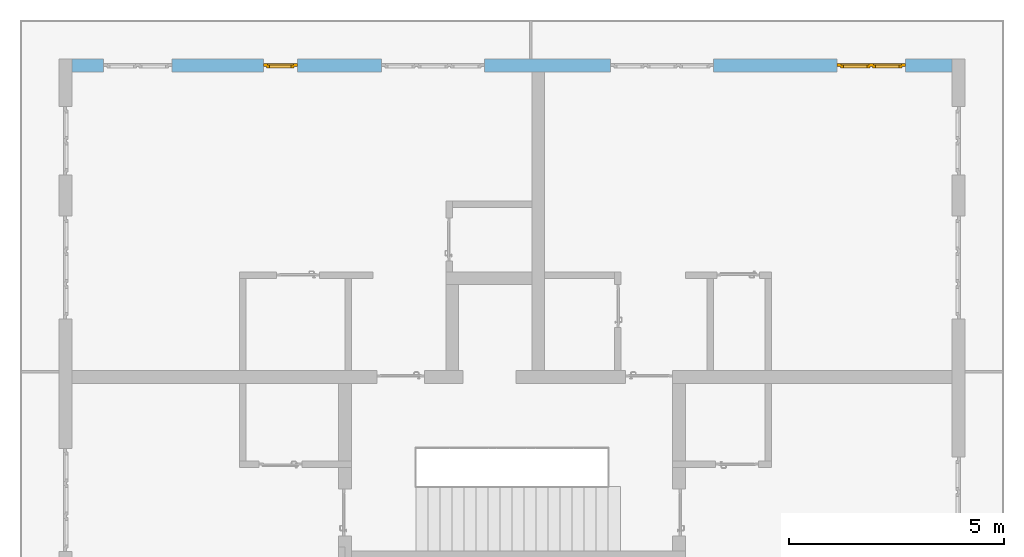
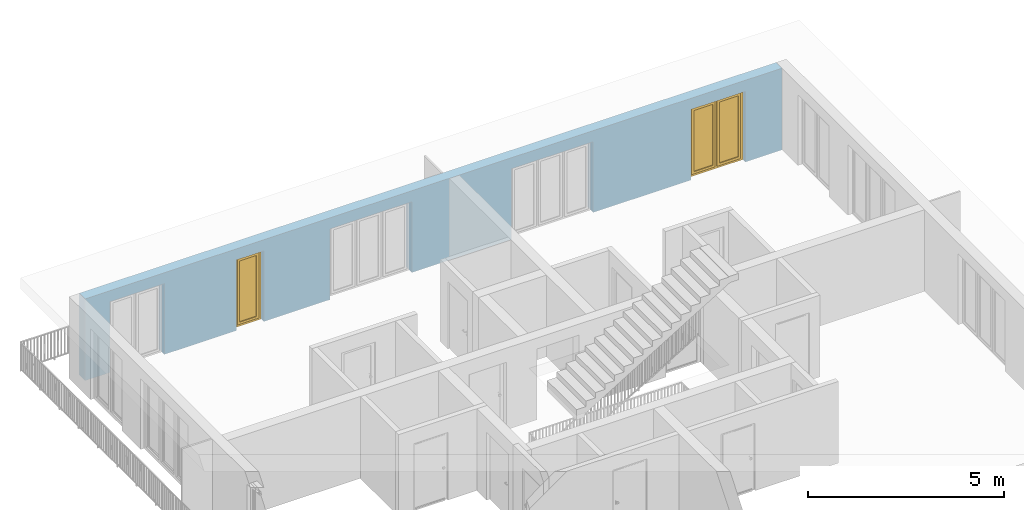
# One storey, part 22 of 48: 2 windows, 5 openings, plus 1 element that does not belong to this part.
"""IFC4 building model written with IfcOpenShell, lengths in metres."""

from ifc_helpers import new_model, entity, si_unit, converted_unit, derived_unit, direction, frame, origin_with_axes, place, context, subcontext, project, spatial, polygons, source, transform, mapped, material, type_object, element, fill, save


model = new_model("IFC4")

# Units and contexts
model_context = context("Model", 3, precision=1e-05, world=origin_with_axes(), true_north=direction((0.0, 1.0)))
body_context = subcontext(model_context, "Body", "Model", "MODEL_VIEW")
ifc_project = project(units=[si_unit("LENGTHUNIT", "METRE"), si_unit("AREAUNIT", "SQUARE_METRE"), si_unit("VOLUMEUNIT", "CUBIC_METRE"), converted_unit("PLANEANGLEUNIT", "DEGREE", entity("IfcPlaneAngleMeasure", 0.0174532925199), si_unit("PLANEANGLEUNIT", "RADIAN"), dimensions=[0, 0, 0, 0, 0, 0, 0]), converted_unit("TIMEUNIT", "Year", entity("IfcTimeMeasure", 31556926.0), si_unit("TIMEUNIT", "SECOND"), dimensions=[0, 0, 1, 0, 0, 0, 0]), si_unit("MASSUNIT", "GRAM", prefix="KILO"), si_unit("THERMODYNAMICTEMPERATUREUNIT", "DEGREE_CELSIUS"), si_unit("LUMINOUSINTENSITYUNIT", "LUMEN"), si_unit("ENERGYUNIT", "JOULE", prefix="MEGA"), derived_unit("THERMALCONDUCTANCEUNIT", [(si_unit("POWERUNIT", "WATT"), 1), (si_unit("LENGTHUNIT", "METRE"), -1), (si_unit("THERMODYNAMICTEMPERATUREUNIT", "KELVIN"), -1)]), derived_unit("SPECIFICHEATCAPACITYUNIT", [(si_unit("ENERGYUNIT", "JOULE"), 1), (si_unit("MASSUNIT", "GRAM", prefix="KILO"), -1), (si_unit("THERMODYNAMICTEMPERATUREUNIT", "KELVIN"), -1)]), derived_unit("MASSDENSITYUNIT", [(si_unit("MASSUNIT", "GRAM", prefix="KILO"), 1), (si_unit("VOLUMEUNIT", "CUBIC_METRE"), -1)])], contexts=[model_context])

# Site, building, storey
site_placement = place(None, origin_with_axes())
site = spatial("IfcSite", under=ifc_project, at=site_placement, CompositionType="ELEMENT")
building_placement = place(site_placement, origin_with_axes())
building = spatial("IfcBuilding", under=site, at=building_placement, CompositionType="ELEMENT")
storey_placement = place(building_placement, frame((0.0, 0.0, 3.4), z_axis=(0.0, 0.0, 1.0), x_axis=(1.0, 0.0, 0.0)))
storey = spatial("IfcBuildingStorey", under=building, at=storey_placement, Name="1. Geschoss", CompositionType="ELEMENT", Elevation=3.4)

# Wall, openings, windows
ifc_material = material()
wall_type = type_object("IfcWallType", Name="300", PredefinedType="NOTDEFINED")
wall_placement = place(storey_placement, frame((-11.7421993804, 8.92118776896, 0.0), z_axis=(0.0, 0.0, 1.0), x_axis=(1.0, 0.0, 0.0)))
wall = element("IfcWall", 1, at=wall_placement, inside=storey, type_object=wall_type, material=ifc_material, Name="Wand-001", PredefinedType="NOTDEFINED", context=body_context, shape_type="Tessellation", body=[
    polygons([(15.23, -0.1, 0.0), (15.23, -0.3, 0.0), (15.23, -0.3, 2.2), (15.23, 0.0, 2.2), (15.23, 0.0, 0.0), (18.102139809, 0.0, 0.0), (18.102139809, -0.3, 0.0), (18.102139809, -0.3, 2.2), (19.702139809, -0.3, 2.2), (19.702139809, -0.3, 0.0), (20.78, -0.3, 0.0), (20.78, -0.3, 2.54), (0.3, -0.3, 2.54), (0.3, -0.3, 0.0), (1.0288518641, -0.3, 0.0), (1.0288518641, -0.3, 2.2), (2.6288518641, -0.3, 2.2), (2.6288518641, -0.3, 0.0), (4.75, -0.3, 0.0), (4.75, -0.3, 2.2), (5.55, -0.3, 2.2), (5.55, -0.3, 0.0), (7.50089858046, -0.3, 0.0), (7.50089858046, -0.3, 2.2), (9.90089858046, -0.3, 2.2), (9.90089858046, -0.3, 0.0), (12.83, -0.3, 0.0), (12.83, -0.3, 2.2), (12.83, 0.0, 2.2), (12.83, 0.0, 0.0), (9.90089858046, 0.0, 0.0), (9.90089858046, 0.0, 2.2), (7.50089858046, 0.0, 2.2), (7.50089858046, 0.0, 0.0), (5.55, 0.0, 0.0), (5.55, 0.0, 2.2), (4.75, 0.0, 2.2), (4.75, 0.0, 0.0), (2.6288518641, 0.0, 0.0), (2.6288518641, 0.0, 2.2), (1.0288518641, 0.0, 2.2), (1.0288518641, 0.0, 0.0), (0.3, 0.0, 0.0), (0.3, 0.0, 2.54), (20.78, 0.0, 2.54), (20.78, 0.0, 0.0), (19.702139809, 0.0, 0.0), (19.702139809, 0.0, 2.2), (18.102139809, 0.0, 2.2), (12.83, -0.1, 0.0)], [[[1, 2, 3, 4, 5]], [[2, 1, 5, 6, 7]], [[3, 2, 7, 8, 9, 10, 11, 12, 13, 14, 15, 16, 17, 18, 19, 20, 21, 22, 23, 24, 25, 26, 27, 28]], [[4, 3, 28, 29]], [[6, 5, 4, 29, 30, 31, 32, 33, 34, 35, 36, 37, 38, 39, 40, 41, 42, 43, 44, 45, 46, 47, 48, 49]], [[6, 49, 8, 7]], [[8, 49, 48, 9]], [[48, 47, 10, 9]], [[46, 11, 10, 47]], [[12, 11, 46, 45]], [[45, 44, 13, 12]], [[44, 43, 14, 13]], [[15, 14, 43, 42]], [[16, 15, 42, 41]], [[40, 17, 16, 41]], [[18, 17, 40, 39]], [[19, 18, 39, 38]], [[20, 19, 38, 37]], [[36, 21, 20, 37]], [[22, 21, 36, 35]], [[22, 35, 34, 23]], [[34, 33, 24, 23]], [[24, 33, 32, 25]], [[32, 31, 26, 25]], [[50, 27, 26, 31, 30]], [[28, 27, 50, 30, 29]]], closed=True),
])
opening_1_placement = place(wall_placement, frame((1.8288518641, 0.0, 0.0), z_axis=(0.0, 0.0, 1.0), x_axis=(1.0, 0.0, 0.0)))
element("IfcOpeningElement", 2, at=opening_1_placement, cuts=wall, Name="Fenster-001", context=body_context, identifier="Reference", shape_type="Tessellation", body=[
    polygons([(-0.8, -0.1, 0.0), (-0.8, -0.1, 2.2), (-0.8, 0.000999999999998, 2.2), (-0.8, 0.000999999999998, 0.0), (-0.8, -0.301, 0.0), (-0.8, -0.301, 2.2), (0.8, -0.1, 2.2), (0.8, 0.000999999999999, 2.2), (0.8, -0.301, 2.2), (0.8, 0.000999999999999, 0.0), (0.8, -0.1, 0.0), (0.8, -0.301, 0.0)], [[[1, 2, 3, 4]], [[2, 1, 5, 6]], [[7, 8, 3, 2, 6, 9]], [[8, 10, 4, 3]], [[1, 4, 10, 11, 12, 5]], [[6, 5, 12, 9]], [[7, 11, 10, 8]], [[11, 7, 9, 12]]], closed=True),
])
opening_2_placement = place(wall_placement, frame((8.70089858046, 0.0, 0.0), z_axis=(0.0, 0.0, 1.0), x_axis=(1.0, 0.0, 0.0)))
element("IfcOpeningElement", 3, at=opening_2_placement, cuts=wall, Name="Fenster-002", context=body_context, identifier="Reference", shape_type="Tessellation", body=[
    polygons([(-1.2, -0.1, 0.0), (-1.2, -0.1, 2.2), (-1.2, 0.000999999999999, 2.2), (-1.2, 0.000999999999999, 0.0), (-1.2, -0.301, 0.0), (-1.2, -0.301, 2.2), (1.2, -0.1, 2.2), (1.2, 0.001, 2.2), (1.2, -0.301, 2.2), (1.2, 0.001, 0.0), (1.2, -0.1, 0.0), (1.2, -0.301, 0.0)], [[[1, 2, 3, 4]], [[2, 1, 5, 6]], [[7, 8, 3, 2, 6, 9]], [[8, 10, 4, 3]], [[1, 4, 10, 11, 12, 5]], [[6, 5, 12, 9]], [[7, 11, 10, 8]], [[11, 7, 9, 12]]], closed=True),
])
opening_3_placement = place(wall_placement, frame((5.15, 0.0, 0.0), z_axis=(0.0, 0.0, 1.0), x_axis=(1.0, 0.0, 0.0)))
opening_3 = element("IfcOpeningElement", 4, at=opening_3_placement, cuts=wall, Name="Fenster-003", context=body_context, identifier="Reference", shape_type="Tessellation", body=[
    polygons([(-0.4, -0.1, 0.0), (-0.4, -0.1, 2.2), (-0.4, 0.001, 2.2), (-0.4, 0.001, 0.0), (-0.4, -0.301, 0.0), (-0.4, -0.301, 2.2), (0.4, -0.1, 2.2), (0.4, 0.001, 2.2), (0.4, -0.301, 2.2), (0.4, 0.001, 0.0), (0.4, -0.1, 0.0), (0.4, -0.301, 0.0)], [[[1, 2, 3, 4]], [[2, 1, 5, 6]], [[7, 8, 3, 2, 6, 9]], [[8, 10, 4, 3]], [[1, 4, 10, 11, 12, 5]], [[6, 5, 12, 9]], [[7, 11, 10, 8]], [[11, 7, 9, 12]]], closed=True),
])
opening_4_placement = place(wall_placement, frame((18.902139809, 0.0, 0.0), z_axis=(0.0, 0.0, 1.0), x_axis=(1.0, 0.0, 0.0)))
opening_4 = element("IfcOpeningElement", 5, at=opening_4_placement, cuts=wall, Name="Fenster-001", context=body_context, identifier="Reference", shape_type="Tessellation", body=[
    polygons([(-0.8, -0.1, 0.0), (-0.8, -0.1, 2.2), (-0.8, 0.001, 2.2), (-0.8, 0.001, 0.0), (-0.8, -0.301, 0.0), (-0.8, -0.301, 2.2), (0.8, -0.1, 2.2), (0.8, 0.001, 2.2), (0.8, -0.301, 2.2), (0.8, 0.001, 0.0), (0.8, -0.1, 0.0), (0.8, -0.301, 0.0)], [[[1, 2, 3, 4]], [[2, 1, 5, 6]], [[7, 8, 3, 2, 6, 9]], [[8, 10, 4, 3]], [[1, 4, 10, 11, 12, 5]], [[6, 5, 12, 9]], [[7, 11, 10, 8]], [[11, 7, 9, 12]]], closed=True),
])
opening_5_placement = place(wall_placement, frame((14.03, 0.0, 0.0), z_axis=(0.0, 0.0, 1.0), x_axis=(1.0, 0.0, 0.0)))
element("IfcOpeningElement", 6, at=opening_5_placement, cuts=wall, Name="Fenster-002", context=body_context, identifier="Reference", shape_type="Tessellation", body=[
    polygons([(-1.2, -0.1, 0.0), (-1.2, -0.1, 2.2), (-1.2, 0.001, 2.2), (-1.2, 0.001, 0.0), (-1.2, -0.301, 0.0), (-1.2, -0.301, 2.2), (1.2, -0.1, 2.2), (1.2, 0.001, 2.2), (1.2, -0.301, 2.2), (1.2, 0.001, 0.0), (1.2, -0.1, 0.0), (1.2, -0.301, 0.0)], [[[1, 2, 3, 4]], [[2, 1, 5, 6]], [[7, 8, 3, 2, 6, 9]], [[8, 10, 4, 3]], [[1, 4, 10, 11, 12, 5]], [[6, 5, 12, 9]], [[7, 11, 10, 8]], [[11, 7, 9, 12]]], closed=True),
])
window_type_1 = type_object("IfcWindowType", Name="2-1+1 26", PartitioningType="DOUBLE_PANEL_VERTICAL", PredefinedType="WINDOW")
shared_shape_1 = source(origin_with_axes(), body_context, "Body", "Tessellation", [
    polygons([(-0.8, -0.07, 0.0), (-0.8, 0.0, 0.0), (-0.7, 0.0, 0.1), (-0.7, -0.07, 0.1), (-0.8, -0.07, 2.2), (-0.8, 0.0, 2.2), (-0.7, 0.0, 2.1), (-0.7, -0.07, 2.1)], [[[1, 2, 3, 4]], [[5, 6, 2, 1]], [[2, 6, 7, 3]], [[4, 3, 7, 8]], [[1, 4, 8, 5]], [[8, 7, 6, 5]]], closed=True),
    polygons([(0.8, -0.07, 0.0), (0.8, 0.0, 0.0), (0.8, 0.0, 2.2), (0.8, -0.07, 2.2), (0.7, -0.07, 0.1), (0.7, 0.0, 0.1), (0.7, 0.0, 2.1), (0.7, -0.07, 2.1)], [[[1, 2, 3, 4]], [[5, 6, 2, 1]], [[2, 6, 7, 3]], [[4, 3, 7, 8]], [[1, 4, 8, 5]], [[8, 7, 6, 5]]], closed=True),
    polygons([(-0.8, -0.07, 0.0), (-0.8, 0.0, 0.0), (0.8, 0.0, 0.0), (0.8, -0.07, 0.0), (-0.7, -0.07, 0.1), (-0.7, 0.0, 0.1), (-0.05, 0.0, 0.1), (0.05, 0.0, 0.1), (0.7, 0.0, 0.1), (0.7, -0.07, 0.1), (0.05, -0.07, 0.1), (-0.05, -0.07, 0.1)], [[[1, 2, 3, 4]], [[5, 6, 2, 1]], [[2, 6, 7, 8, 9, 3]], [[4, 3, 9, 10]], [[1, 4, 10, 11, 12, 5]], [[12, 7, 6, 5]], [[11, 8, 7, 12]], [[10, 9, 8, 11]]], closed=True),
    polygons([(-0.8, -0.07, 2.2), (-0.8, 0.0, 2.2), (-0.7, 0.0, 2.1), (-0.7, -0.07, 2.1), (0.8, -0.07, 2.2), (0.8, 0.0, 2.2), (0.7, 0.0, 2.1), (0.05, 0.0, 2.1), (-0.05, 0.0, 2.1), (-0.05, -0.07, 2.1), (0.05, -0.07, 2.1), (0.7, -0.07, 2.1)], [[[1, 2, 3, 4]], [[5, 6, 2, 1]], [[2, 6, 7, 8, 9, 3]], [[4, 3, 9, 10]], [[1, 4, 10, 11, 12, 5]], [[12, 7, 6, 5]], [[11, 8, 7, 12]], [[10, 9, 8, 11]]], closed=True),
    polygons([(-0.05, -0.07, 0.1), (-0.05, 0.0, 0.1), (0.05, 0.0, 0.1), (0.05, -0.07, 0.1), (-0.05, -0.07, 2.1), (-0.05, 0.0, 2.1), (0.05, 0.0, 2.1), (0.05, -0.07, 2.1)], [[[1, 2, 3, 4]], [[5, 6, 2, 1]], [[2, 6, 7, 3]], [[4, 3, 7, 8]], [[1, 4, 8, 5]], [[8, 7, 6, 5]]], closed=True),
    polygons([(-0.72, 0.0, 0.08), (-0.72, 0.03, 0.08), (-0.65, 0.03, 0.15), (-0.65, 0.0, 0.15), (-0.72, 0.0, 2.12), (-0.72, 0.03, 2.12), (-0.65, 0.03, 2.05), (-0.65, 0.0, 2.05)], [[[1, 2, 3, 4]], [[5, 6, 2, 1]], [[2, 6, 7, 3]], [[4, 3, 7, 8]], [[1, 4, 8, 5]], [[8, 7, 6, 5]]], closed=True),
    polygons([(-0.03, 0.0, 0.08), (-0.1, 0.0, 0.15), (-0.1, 0.03, 0.15), (-0.03, 0.03, 0.08), (-0.03, 0.0, 2.12), (-0.1, 0.0, 2.05), (-0.1, 0.03, 2.05), (-0.03, 0.03, 2.12)], [[[1, 2, 3, 4]], [[1, 5, 6, 2]], [[2, 6, 7, 3]], [[4, 3, 7, 8]], [[5, 1, 4, 8]], [[6, 5, 8, 7]]], closed=True),
    polygons([(-0.72, 0.0, 0.08), (-0.72, 0.03, 0.08), (-0.03, 0.03, 0.08), (-0.03, 0.0, 0.08), (-0.65, 0.0, 0.15), (-0.65, 0.03, 0.15), (-0.1, 0.03, 0.15), (-0.1, 0.0, 0.15)], [[[1, 2, 3, 4]], [[5, 6, 2, 1]], [[2, 6, 7, 3]], [[4, 3, 7, 8]], [[1, 4, 8, 5]], [[8, 7, 6, 5]]], closed=True),
    polygons([(-0.72, 0.0, 2.12), (-0.03, 0.0, 2.12), (-0.03, 0.03, 2.12), (-0.72, 0.03, 2.12), (-0.65, 0.0, 2.05), (-0.1, 0.0, 2.05), (-0.1, 0.03, 2.05), (-0.65, 0.03, 2.05)], [[[1, 2, 3, 4]], [[1, 5, 6, 2]], [[2, 6, 7, 3]], [[4, 3, 7, 8]], [[5, 1, 4, 8]], [[6, 5, 8, 7]]], closed=True),
    polygons([(-0.7, -0.03, 0.1), (-0.7, 0.0, 0.1), (-0.65, 0.0, 0.15), (-0.65, -0.03, 0.15), (-0.7, -0.03, 2.1), (-0.7, 0.0, 2.1), (-0.65, 0.0, 2.05), (-0.65, -0.03, 2.05)], [[[1, 2, 3, 4]], [[5, 6, 2, 1]], [[2, 6, 7, 3]], [[4, 3, 7, 8]], [[1, 4, 8, 5]], [[8, 7, 6, 5]]], closed=True),
    polygons([(-0.05, -0.03, 0.1), (-0.1, -0.03, 0.15), (-0.1, 0.0, 0.15), (-0.05, 0.0, 0.1), (-0.05, -0.03, 2.1), (-0.1, -0.03, 2.05), (-0.1, 0.0, 2.05), (-0.05, 0.0, 2.1)], [[[1, 2, 3, 4]], [[1, 5, 6, 2]], [[2, 6, 7, 3]], [[4, 3, 7, 8]], [[5, 1, 4, 8]], [[6, 5, 8, 7]]], closed=True),
    polygons([(-0.7, -0.03, 0.1), (-0.7, 0.0, 0.1), (-0.05, 0.0, 0.1), (-0.05, -0.03, 0.1), (-0.65, -0.03, 0.15), (-0.65, 0.0, 0.15), (-0.1, 0.0, 0.15), (-0.1, -0.03, 0.15)], [[[1, 2, 3, 4]], [[5, 6, 2, 1]], [[2, 6, 7, 3]], [[4, 3, 7, 8]], [[1, 4, 8, 5]], [[8, 7, 6, 5]]], closed=True),
    polygons([(-0.7, -0.03, 2.1), (-0.05, -0.03, 2.1), (-0.05, 0.0, 2.1), (-0.7, 0.0, 2.1), (-0.65, -0.03, 2.05), (-0.1, -0.03, 2.05), (-0.1, 0.0, 2.05), (-0.65, 0.0, 2.05)], [[[1, 2, 3, 4]], [[1, 5, 6, 2]], [[2, 6, 7, 3]], [[4, 3, 7, 8]], [[5, 1, 4, 8]], [[6, 5, 8, 7]]], closed=True),
    polygons([(-0.65, -0.005, 0.15), (-0.65, 0.005, 0.15), (-0.1, 0.005, 0.15), (-0.1, -0.005, 0.15), (-0.65, -0.005, 2.05), (-0.65, 0.005, 2.05), (-0.1, 0.005, 2.05), (-0.1, -0.005, 2.05)], [[[1, 2, 3, 4]], [[5, 6, 2, 1]], [[2, 6, 7, 3]], [[4, 3, 7, 8]], [[1, 4, 8, 5]], [[8, 7, 6, 5]]], closed=True),
    polygons([(0.03, 0.0, 0.08), (0.03, 0.03, 0.08), (0.1, 0.03, 0.15), (0.1, 0.0, 0.15), (0.03, 0.0, 2.12), (0.03, 0.03, 2.12), (0.1, 0.03, 2.05), (0.1, 0.0, 2.05)], [[[1, 2, 3, 4]], [[5, 6, 2, 1]], [[2, 6, 7, 3]], [[4, 3, 7, 8]], [[1, 4, 8, 5]], [[8, 7, 6, 5]]], closed=True),
    polygons([(0.72, 0.0, 0.08), (0.65, 0.0, 0.15), (0.65, 0.03, 0.15), (0.72, 0.03, 0.08), (0.72, 0.0, 2.12), (0.65, 0.0, 2.05), (0.65, 0.03, 2.05), (0.72, 0.03, 2.12)], [[[1, 2, 3, 4]], [[1, 5, 6, 2]], [[2, 6, 7, 3]], [[4, 3, 7, 8]], [[5, 1, 4, 8]], [[6, 5, 8, 7]]], closed=True),
    polygons([(0.03, 0.0, 0.08), (0.03, 0.03, 0.08), (0.72, 0.03, 0.08), (0.72, 0.0, 0.08), (0.1, 0.0, 0.15), (0.1, 0.03, 0.15), (0.65, 0.03, 0.15), (0.65, 0.0, 0.15)], [[[1, 2, 3, 4]], [[5, 6, 2, 1]], [[2, 6, 7, 3]], [[4, 3, 7, 8]], [[1, 4, 8, 5]], [[8, 7, 6, 5]]], closed=True),
    polygons([(0.03, 0.0, 2.12), (0.72, 0.0, 2.12), (0.72, 0.03, 2.12), (0.03, 0.03, 2.12), (0.1, 0.0, 2.05), (0.65, 0.0, 2.05), (0.65, 0.03, 2.05), (0.1, 0.03, 2.05)], [[[1, 2, 3, 4]], [[1, 5, 6, 2]], [[2, 6, 7, 3]], [[4, 3, 7, 8]], [[5, 1, 4, 8]], [[6, 5, 8, 7]]], closed=True),
    polygons([(0.05, -0.03, 0.1), (0.05, 0.0, 0.1), (0.1, 0.0, 0.15), (0.1, -0.03, 0.15), (0.05, -0.03, 2.1), (0.05, 0.0, 2.1), (0.1, 0.0, 2.05), (0.1, -0.03, 2.05)], [[[1, 2, 3, 4]], [[5, 6, 2, 1]], [[2, 6, 7, 3]], [[4, 3, 7, 8]], [[1, 4, 8, 5]], [[8, 7, 6, 5]]], closed=True),
    polygons([(0.7, -0.03, 0.1), (0.65, -0.03, 0.15), (0.65, 0.0, 0.15), (0.7, 0.0, 0.1), (0.7, -0.03, 2.1), (0.65, -0.03, 2.05), (0.65, 0.0, 2.05), (0.7, 0.0, 2.1)], [[[1, 2, 3, 4]], [[1, 5, 6, 2]], [[2, 6, 7, 3]], [[4, 3, 7, 8]], [[5, 1, 4, 8]], [[6, 5, 8, 7]]], closed=True),
    polygons([(0.05, -0.03, 0.1), (0.05, 0.0, 0.1), (0.7, 0.0, 0.1), (0.7, -0.03, 0.1), (0.1, -0.03, 0.15), (0.1, 0.0, 0.15), (0.65, 0.0, 0.15), (0.65, -0.03, 0.15)], [[[1, 2, 3, 4]], [[5, 6, 2, 1]], [[2, 6, 7, 3]], [[4, 3, 7, 8]], [[1, 4, 8, 5]], [[8, 7, 6, 5]]], closed=True),
    polygons([(0.05, -0.03, 2.1), (0.7, -0.03, 2.1), (0.7, 0.0, 2.1), (0.05, 0.0, 2.1), (0.1, -0.03, 2.05), (0.65, -0.03, 2.05), (0.65, 0.0, 2.05), (0.1, 0.0, 2.05)], [[[1, 2, 3, 4]], [[1, 5, 6, 2]], [[2, 6, 7, 3]], [[4, 3, 7, 8]], [[5, 1, 4, 8]], [[6, 5, 8, 7]]], closed=True),
    polygons([(0.1, -0.005, 0.15), (0.1, 0.005, 0.15), (0.65, 0.005, 0.15), (0.65, -0.005, 0.15), (0.1, -0.005, 2.05), (0.1, 0.005, 2.05), (0.65, 0.005, 2.05), (0.65, -0.005, 2.05)], [[[1, 2, 3, 4]], [[5, 6, 2, 1]], [[2, 6, 7, 3]], [[4, 3, 7, 8]], [[1, 4, 8, 5]], [[8, 7, 6, 5]]], closed=True),
])
window_1_placement = place(opening_4_placement, frame((0.8, 0.0, 0.0), z_axis=(0.0, 0.0, 1.0), x_axis=(-1.0, 0.0, 0.0)))
window_1 = element("IfcWindow", 7, at=window_1_placement, inside=storey, type_object=window_type_1, Name="Fenster-001", OverallHeight=2.2, OverallWidth=1.6, PredefinedType="WINDOW", context=body_context, shape_type="MappedRepresentation", body=[
    mapped(shared_shape_1, transform((0.8, 0.17, 0.0))),
])
fill(opening_4, window_1)
window_type_2 = type_object("IfcWindowType", Name="1-26", PartitioningType="SINGLE_PANEL", PredefinedType="WINDOW")
shared_shape_2 = source(origin_with_axes(), body_context, "Body", "Tessellation", [
    polygons([(0.4, -0.07, 0.0), (0.3, -0.07, 0.1), (0.3, 0.0, 0.1), (0.4, 0.0, 0.0), (0.4, -0.07, 2.2), (0.3, -0.07, 2.1), (0.3, 0.0, 2.1), (0.4, 0.0, 2.2)], [[[1, 2, 3, 4]], [[1, 5, 6, 2]], [[2, 6, 7, 3]], [[4, 3, 7, 8]], [[5, 1, 4, 8]], [[6, 5, 8, 7]]], closed=True),
    polygons([(-0.4, -0.07, 0.0), (-0.4, -0.07, 2.2), (-0.4, 0.0, 2.2), (-0.4, 0.0, 0.0), (-0.3, -0.07, 0.1), (-0.3, -0.07, 2.1), (-0.3, 0.0, 2.1), (-0.3, 0.0, 0.1)], [[[1, 2, 3, 4]], [[1, 5, 6, 2]], [[2, 6, 7, 3]], [[4, 3, 7, 8]], [[5, 1, 4, 8]], [[6, 5, 8, 7]]], closed=True),
    polygons([(0.4, -0.07, 0.0), (-0.4, -0.07, 0.0), (-0.4, 0.0, 0.0), (0.4, 0.0, 0.0), (0.3, -0.07, 0.1), (0.0, -0.07, 0.1), (-0.3, -0.07, 0.1), (-0.3, 0.0, 0.1), (0.0, 0.0, 0.1), (0.3, 0.0, 0.1)], [[[1, 2, 3, 4]], [[1, 5, 6, 7, 2]], [[2, 7, 8, 3]], [[4, 3, 8, 9, 10]], [[5, 1, 4, 10]], [[6, 5, 10, 9]], [[7, 6, 9, 8]]], closed=True),
    polygons([(0.4, -0.07, 2.2), (0.3, -0.07, 2.1), (0.3, 0.0, 2.1), (0.4, 0.0, 2.2), (-0.4, -0.07, 2.2), (-0.3, -0.07, 2.1), (0.0, -0.07, 2.1), (0.0, 0.0, 2.1), (-0.3, 0.0, 2.1), (-0.4, 0.0, 2.2)], [[[1, 2, 3, 4]], [[1, 5, 6, 7, 2]], [[2, 7, 8, 3]], [[4, 3, 8, 9, 10]], [[5, 1, 4, 10]], [[6, 5, 10, 9]], [[7, 6, 9, 8]]], closed=True),
    polygons([(0.32, 0.0, 0.08), (0.25, 0.0, 0.15), (0.25, 0.03, 0.15), (0.32, 0.03, 0.08), (0.32, 0.0, 2.12), (0.25, 0.0, 2.05), (0.25, 0.03, 2.05), (0.32, 0.03, 2.12)], [[[1, 2, 3, 4]], [[1, 5, 6, 2]], [[2, 6, 7, 3]], [[4, 3, 7, 8]], [[5, 1, 4, 8]], [[6, 5, 8, 7]]], closed=True),
    polygons([(-0.32, 0.0, 0.08), (-0.32, 0.03, 0.08), (-0.25, 0.03, 0.15), (-0.25, 0.0, 0.15), (-0.32, 0.0, 2.12), (-0.32, 0.03, 2.12), (-0.25, 0.03, 2.05), (-0.25, 0.0, 2.05)], [[[1, 2, 3, 4]], [[5, 6, 2, 1]], [[2, 6, 7, 3]], [[4, 3, 7, 8]], [[1, 4, 8, 5]], [[8, 7, 6, 5]]], closed=True),
    polygons([(0.32, 0.0, 0.08), (-0.32, 0.0, 0.08), (-0.32, 0.03, 0.08), (0.32, 0.03, 0.08), (0.25, 0.0, 0.15), (-0.25, 0.0, 0.15), (-0.25, 0.03, 0.15), (0.25, 0.03, 0.15)], [[[1, 2, 3, 4]], [[1, 5, 6, 2]], [[2, 6, 7, 3]], [[4, 3, 7, 8]], [[5, 1, 4, 8]], [[6, 5, 8, 7]]], closed=True),
    polygons([(0.32, 0.0, 2.12), (0.32, 0.03, 2.12), (-0.32, 0.03, 2.12), (-0.32, 0.0, 2.12), (0.25, 0.0, 2.05), (0.25, 0.03, 2.05), (-0.25, 0.03, 2.05), (-0.25, 0.0, 2.05)], [[[1, 2, 3, 4]], [[5, 6, 2, 1]], [[2, 6, 7, 3]], [[4, 3, 7, 8]], [[1, 4, 8, 5]], [[8, 7, 6, 5]]], closed=True),
    polygons([(0.3, -0.03, 0.1), (0.25, -0.03, 0.15), (0.25, 0.0, 0.15), (0.3, 0.0, 0.1), (0.3, -0.03, 2.1), (0.25, -0.03, 2.05), (0.25, 0.0, 2.05), (0.3, 0.0, 2.1)], [[[1, 2, 3, 4]], [[1, 5, 6, 2]], [[2, 6, 7, 3]], [[4, 3, 7, 8]], [[5, 1, 4, 8]], [[6, 5, 8, 7]]], closed=True),
    polygons([(-0.3, -0.03, 0.1), (-0.3, 0.0, 0.1), (-0.25, 0.0, 0.15), (-0.25, -0.03, 0.15), (-0.3, -0.03, 2.1), (-0.3, 0.0, 2.1), (-0.25, 0.0, 2.05), (-0.25, -0.03, 2.05)], [[[1, 2, 3, 4]], [[5, 6, 2, 1]], [[2, 6, 7, 3]], [[4, 3, 7, 8]], [[1, 4, 8, 5]], [[8, 7, 6, 5]]], closed=True),
    polygons([(0.3, -0.03, 0.1), (-0.3, -0.03, 0.1), (-0.3, 0.0, 0.1), (0.3, 0.0, 0.1), (0.25, -0.03, 0.15), (-0.25, -0.03, 0.15), (-0.25, 0.0, 0.15), (0.25, 0.0, 0.15)], [[[1, 2, 3, 4]], [[1, 5, 6, 2]], [[2, 6, 7, 3]], [[4, 3, 7, 8]], [[5, 1, 4, 8]], [[6, 5, 8, 7]]], closed=True),
    polygons([(0.3, -0.03, 2.1), (0.3, 0.0, 2.1), (-0.3, 0.0, 2.1), (-0.3, -0.03, 2.1), (0.25, -0.03, 2.05), (0.25, 0.0, 2.05), (-0.25, 0.0, 2.05), (-0.25, -0.03, 2.05)], [[[1, 2, 3, 4]], [[5, 6, 2, 1]], [[2, 6, 7, 3]], [[4, 3, 7, 8]], [[1, 4, 8, 5]], [[8, 7, 6, 5]]], closed=True),
    polygons([(0.25, -0.005, 0.15), (-0.25, -0.005, 0.15), (-0.25, 0.005, 0.15), (0.25, 0.005, 0.15), (0.25, -0.005, 2.05), (-0.25, -0.005, 2.05), (-0.25, 0.005, 2.05), (0.25, 0.005, 2.05)], [[[1, 2, 3, 4]], [[1, 5, 6, 2]], [[2, 6, 7, 3]], [[4, 3, 7, 8]], [[5, 1, 4, 8]], [[6, 5, 8, 7]]], closed=True),
])
window_2_placement = place(opening_3_placement, frame((0.4, 0.0, 0.0), z_axis=(0.0, 0.0, 1.0), x_axis=(-1.0, 0.0, 0.0)))
window_2 = element("IfcWindow", 8, at=window_2_placement, inside=storey, type_object=window_type_2, Name="Fenster-003", OverallHeight=2.2, OverallWidth=0.8, PredefinedType="WINDOW", context=body_context, shape_type="MappedRepresentation", body=[
    mapped(shared_shape_2, transform((0.4, 0.17, 0.0))),
])
fill(opening_3, window_2)

save(model, "model.ifc")
